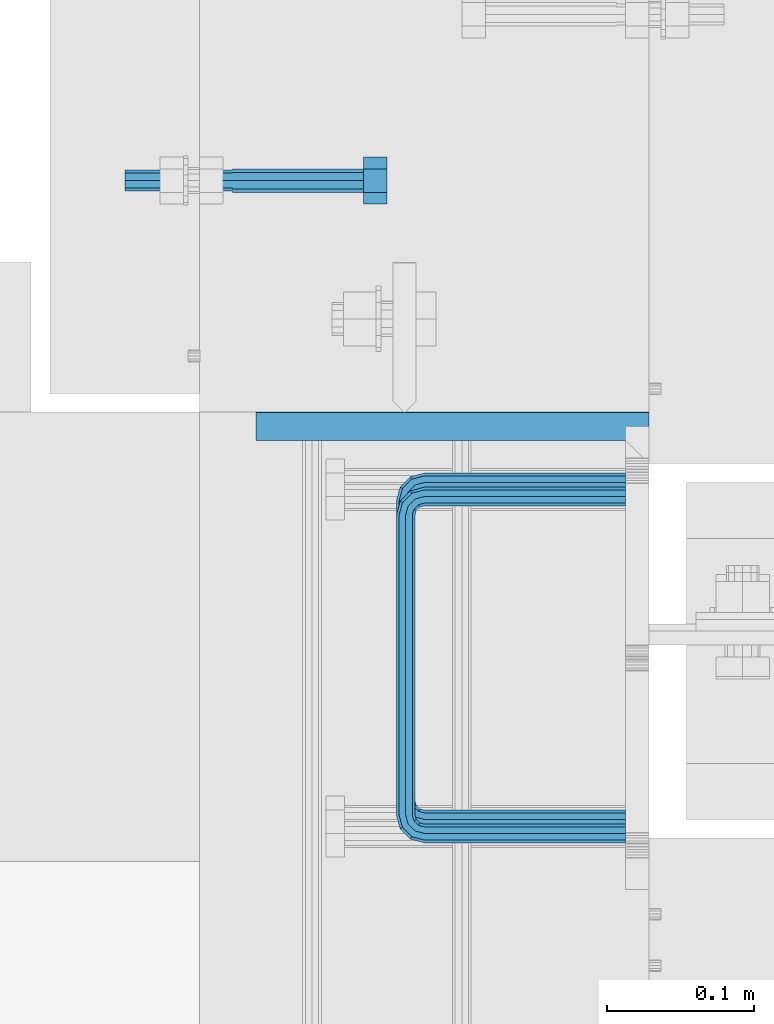
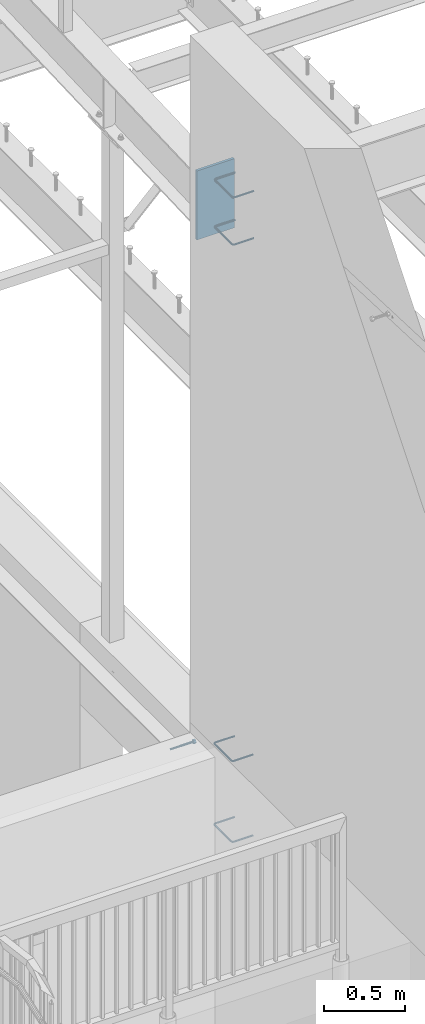
# One storey, part 380 of 975: 6 beams.
"""IFC2X3 building model written with IfcOpenShell, lengths in millimetres."""

from ifc_helpers import new_model, si_unit, frame, origin_with_axes, place, context, subcontext, project, spatial, faceted_brep, material, type_object, element, save


model = new_model("IFC2X3")

# Units and contexts
model_context = context("Model", 3, precision=1e-05, world=origin_with_axes())
body_context = subcontext(model_context, "Body", "Model", "MODEL_VIEW")
ifc_project = project(units=[si_unit("LENGTHUNIT", "METRE", prefix="MILLI"), si_unit("AREAUNIT", "SQUARE_METRE"), si_unit("VOLUMEUNIT", "CUBIC_METRE"), si_unit("MASSUNIT", "GRAM", prefix="KILO"), si_unit("TIMEUNIT", "SECOND"), si_unit("PLANEANGLEUNIT", "RADIAN"), si_unit("SOLIDANGLEUNIT", "STERADIAN"), si_unit("THERMODYNAMICTEMPERATUREUNIT", "DEGREE_CELSIUS"), si_unit("LUMINOUSINTENSITYUNIT", "LUMEN")], contexts=[model_context])

# Site, building, storey
site_placement = place(None, origin_with_axes())
site = spatial("IfcSite", under=ifc_project, at=site_placement, CompositionType="ELEMENT")
building_placement = place(site_placement, origin_with_axes())
building = spatial("IfcBuilding", under=site, at=building_placement, Name="Undefined", CompositionType="ELEMENT")
storey_placement = place(building_placement, origin_with_axes())
storey = spatial("IfcBuildingStorey", under=building, at=storey_placement, Name="Undefined", CompositionType="ELEMENT", Elevation=0.0)

# Beams
ifc_material_1 = material(Name="STEEL/F1554-36")
beam_type_1 = type_object("IfcBeamType", PredefinedType="NOTDEFINED")
beam_1_placement = place(storey_placement, frame((2038.34997213285, 6138.86245102515, 3835.4), z_axis=(0.0, 0.0, -1.0), x_axis=(1.0, 0.0, 0.0)))
element("IfcBeam", 1, at=beam_1_placement, inside=storey, type_object=beam_type_1, material=ifc_material_1, Name="HEADED_ANCHOR_BOLT", context=body_context, shape_type="Brep", body=[
    faceted_brep([(88.9000000184824, 7.94000001861696, -13.7499999799138), (88.8999999527368, 15.8800000758411, 2.00943759409711e-08), (104.774999952569, 15.8800001213949, 6.97191353538074e-08), (104.775000018315, 7.94000006417082, -13.7499999302891), (88.900000064019, -7.94000009583215, -13.7499999799147), (104.775000063852, -7.9400000502792, -13.74999993029), (88.9000000438027, -15.880000153059, 2.00925569515675e-08), (104.775000043643, -15.8800001075042, 6.9716406869702e-08), (88.8999999780608, -7.94000009583488, 13.7500000200998), (104.774999977893, -7.94000005028101, 13.7500000697237), (88.8999999325279, 7.94000001861514, 13.7500000201007), (104.774999932361, 7.940000064169, 13.7500000697246), (88.9000000119959, 3.78780480527439, -7.86545778426807), (88.8999999957159, 6.82538844544797, -5.4430656647246), (88.8999999799416, 8.51112018845743, -1.94260763148395), (88.8999999677944, 8.51112018845652, 1.94260767167179), (88.8999999616899, 6.82538844544615, 5.44306570491244), (88.8999999628249, 3.78780480527257, 7.86545782445592), (88.8999999709849, -3.86089595849626e-08, 8.72999956233434), (88.8999999845473, -3.7878048824914, 7.8654578244541), (88.9000000008309, -6.82538852266407, 5.44306570491153), (88.9000000166052, -8.51112026567444, 1.94260767166998), (88.9000000287488, -8.51112026567353, -1.94260763148577), (88.9000000348606, -6.82538852266407, -5.44306566472642), (88.9000000337182, -3.78780488248958, -7.86545778426898), (88.9000000255583, -3.86080500902608e-08, -8.72999952214832), (104.775000025395, 6.94581103743985e-09, -8.72999947252447), (104.775000011829, 3.78780485082825, -7.86545773464422), (104.774999995549, 6.82538849100092, -5.44306561510075), (104.774999979774, 8.51112023401038, -1.9426075818601), (104.774999967627, 8.51112023401038, 1.94260772129564), (104.774999961523, 6.82538849100092, 5.44306575453629), (104.774999962658, 3.78780485082643, 7.86545787407977), (104.774999970818, 6.94399204803631e-09, 8.7299996119591), (104.77499998438, -3.78780483693754, 7.86545787407886), (104.775000000664, -6.82538847711112, 5.44306575453538), (104.775000016438, -8.51112022012057, 1.94260772129473), (104.775000028581, -8.51112022012057, -1.94260758186101), (104.775000034693, -6.82538847711021, -5.44306561510166), (104.775000033551, -3.78780483693663, -7.86545773464422), (-2.99107341561466e-07, -5.61266007567065, 5.61266007566792), (-4.22995071858168e-07, -7.93750000000728, 0.0), (104.774999998088, -7.93749999999, -4.45652403868735e-11), (104.774999998088, -5.61266007565791, 5.61266007562426), (-1.09139364212751e-11, 1.81898940354586e-12, 7.9375), (104.774999998095, 1.18234311230481e-11, 7.93749999995816), (2.99089151667431e-07, 5.61266007567428, 5.61266007566792), (104.774999998102, 5.61266007568065, 5.61266007562517), (4.22980519942939e-07, 7.93750000001091, 0.0), (104.77499999811, 7.93750000001364, -4.36557456851006e-11), (2.99089151667431e-07, 5.61266007567428, -5.61266007566792), (104.774999998102, 5.61266007568156, -5.61266007571339), (-1.09139364212751e-11, 1.81898940354586e-12, -7.9375), (104.774999998099, 1.2732925824821e-11, -7.93750000004547), (-73.0249999592124, 5.05157065939329, -5.0515715445581), (-73.0249999269472, -1.85405951924622e-07, -7.14400069976364), (-73.0249999328516, -5.0515710302052, -5.05157154455992), (-73.0249999734697, -7.14400018541073, -6.9975976657588e-07), (-73.0250000250016, -5.05157103020611, 5.05157014504039), (-73.0250000572705, -1.85406861419324e-07, 7.1439993002441), (-73.0250000513661, 5.05157065939238, 5.05157014503948), (-73.025000010748, 7.14399981459792, -6.99758857081179e-07), (0.00625003290042514, 5.05157085007795, -5.05157087849238), (0.00625006516929716, 5.27870724909008e-09, -7.1440000336961), (0.00625005926485755, -5.05157083952145, -5.05157087849329), (0.00625001864682417, -7.14399999472516, -3.36940502165817e-08), (0.00624996711121639, -5.05157083952145, 5.05157081110519), (0.00624993484598235, 5.2777977543883e-09, 7.14399996631164), (0.00624994074678398, 5.05157085007704, 5.05157081110701), (0.00624998136845534, 7.14400000528167, -3.36922312271781e-08), (-2.99107341561466e-07, -5.61266007567065, -5.61266007566792), (104.774999998092, -5.612660075657, -5.6126600757143)], [[[0, 1, 2, 3]], [[4, 0, 3, 5]], [[6, 4, 5, 7]], [[8, 6, 7, 9]], [[10, 8, 9, 11]], [[0, 4, 6, 8, 10, 1], [12, 13, 14, 15, 16, 17, 18, 19, 20, 21, 22, 23, 24, 25]], [[12, 25, 26, 27]], [[13, 12, 27, 28]], [[14, 13, 28, 29]], [[15, 14, 29, 30]], [[16, 15, 30, 31]], [[17, 16, 31, 32]], [[18, 17, 32, 33]], [[19, 18, 33, 34]], [[20, 19, 34, 35]], [[21, 20, 35, 36]], [[22, 21, 36, 37]], [[23, 22, 37, 38]], [[24, 23, 38, 39]], [[25, 24, 39, 26]], [[9, 7, 5, 3, 2, 11], [38, 37, 36, 35, 34, 33, 32, 31, 30, 29, 28, 27, 26, 39]], [[1, 10, 11, 2]], [[40, 41, 42, 43]], [[44, 40, 43, 45]], [[46, 44, 45, 47]], [[48, 46, 47, 49]], [[50, 48, 49, 51]], [[52, 50, 51, 53]], [[54, 55, 56, 57, 58, 59, 60, 61]], [[55, 54, 62, 63]], [[56, 55, 63, 64]], [[57, 56, 64, 65]], [[58, 57, 65, 66]], [[59, 58, 66, 67]], [[60, 59, 67, 68]], [[61, 60, 68, 69]], [[54, 61, 69, 62]], [[40, 44, 46, 48, 50, 52, 70, 41], [68, 67, 66, 65, 64, 63, 62, 69]], [[41, 70, 71, 42]], [[53, 51, 49, 47, 45, 43, 42, 71]], [[70, 52, 53, 71]]]),
])
ifc_material_2 = material(Name="STEEL/A706")
beam_type_2 = type_object("IfcBeamType", Name="#4 TIE", PredefinedType="NOTDEFINED")
beam_2_placement = place(storey_placement, frame((2305.0501035281, 5695.95000864899, 7839.07498779297), z_axis=(0.0, 1.0, 0.0), x_axis=(-0.999999999999998, 6.90000001668524e-08, 0.0)))
element("IfcBeam", 2, at=beam_2_placement, inside=storey, type_object=beam_type_2, material=ifc_material_2, Name="TIE ROD", ObjectType="#4 TIE", context=body_context, shape_type="Brep", body=[
    faceted_brep([(0.0, -6.34999999998763, -3.63797880709171e-12), (0.0, -4.49012806052269, -4.49012806054634), (136.525006144455, -4.49012806053452, -4.49012811661669), (136.525006146271, -6.35000000000036, -5.60821717954241e-08), (0.0, 7.27595761418343e-12, -6.35000000000764), (136.525006143703, 0.0, -6.35000005608254), (0.0, 4.49012806053724, -4.49012806053906), (136.525006144455, 4.49012806053452, -4.49012811661669), (0.0, 6.34999999999491, 5.45696821063757e-12), (136.525006146271, 6.35000000000036, -5.60821717954241e-08), (0.0, 4.49012806052633, 4.49012806054634), (136.525006148087, 4.49012806053452, 4.49012800445234), (0.0, 0.0, 6.35000000000764), (136.525006148839, 0.0, 6.34999994391819), (0.0, -4.49012806053361, 4.49012806053543), (136.525006148087, -4.49012806053452, 4.49012800445234), (146.050006113442, 0.0, -3.79778399058796), (145.120070138105, -4.49012806053452, -2.1870876464609), (142.875006094308, -6.35000000000036, 1.70147731239558), (140.62994205051, -4.49012806053452, 5.59004227125297), (139.700006075173, 0.0, 7.20073861538003), (140.62994205051, 4.49012806053452, 5.59004227125297), (142.875006094308, 6.35000000000036, 1.70147731239558), (145.120070138105, 4.49012806053452, -2.1870876464609), (151.412093644245, 4.49012806053452, 4.10493592790226), (153.022789998455, 0.0, 3.1749999700296), (147.523528661045, 6.35000000000036, 6.34999992953635), (143.634963677846, 4.49012806053452, 8.59506393117135), (142.024267323636, 0.0, 9.5249998890431), (143.634963677846, -4.49012806053452, 8.59506393117135), (147.523528661045, -6.35000000000036, 6.34999992953635), (151.412093644245, -4.49012806053452, 4.10493592790226), (153.715134021207, 4.49012806053452, 12.6999999465306), (155.575005960673, 0.0, 12.6999999674508), (149.225005960672, 6.35000000000036, 12.6999998960273), (144.734877900137, 4.49012806053452, 12.699999845524), (142.875005960672, 0.0, 12.6999998246056), (144.734877900137, -4.49012806053452, 12.699999845524), (149.225005960671, -6.35000000000036, 12.6999998960273), (153.715134021207, -4.49012806053452, 12.6999999465306), (153.71513173569, -4.49012806053452, 215.900003176369), (149.225003675155, -6.35000000000036, 215.900003125867), (155.575003675155, 0.0, 215.900003197289), (153.71513173569, 4.49012806053452, 215.900003176369), (149.225003675155, 6.35000000000036, 215.900003125867), (144.734875614621, 4.49012806053452, 215.900003075363), (142.875003675155, 0.0, 215.900003054444), (144.734875614621, -4.49012806053452, 215.900003075363), (153.022787648382, 0.0, 225.425002877988), (151.412091300475, -4.49012806053452, 224.495066909199), (147.523526332491, -6.35000000000036, 222.25000288121), (143.634961364508, -4.49012806053452, 220.004938853222), (142.024265016601, 0.0, 219.075002884432), (143.634961364508, 4.49012806053452, 220.004938853222), (147.523526332491, 6.35000000000036, 222.25000288121), (151.412091300475, 4.49012806053452, 224.495066909199), (145.120067985683, 4.49012806053452, 230.787090305822), (146.05000397542, 0.0, 232.397786641635), (142.875003907121, 6.35000000000036, 226.898525367037), (140.629939828559, 4.49012806053452, 223.00996042825), (139.700003838822, 0.0, 221.399264092438), (140.629939828559, -4.49012806053452, 223.00996042825), (142.875003907121, -6.35000000000036, 226.898525367037), (145.120067985683, -4.49012806053452, 230.787090305822), (136.525004282814, 4.49012806053452, 233.090130852819), (136.525004327922, 0.0, 234.950002792285), (136.525004173912, 6.35000000000036, 228.600002792285), (136.52500406501, 4.49012806053452, 224.10987473175), (136.525004019901, 0.0, 222.250002792285), (136.52500406501, -4.49012806053452, 224.10987473175), (136.525004173912, -6.35000000000036, 228.600002792286), (136.525004282814, -4.49012806053452, 233.090130852819), (3.32236731992452e-06, -4.49012806053452, 233.090134164055), (3.21346533382894e-06, -6.35000000000036, 228.60000610352), (3.36747552864836e-06, 0.0, 234.95000610352), (3.32236731992452e-06, 4.49012806053452, 233.090134164055), (3.21346533382894e-06, 6.35000000000036, 228.60000610352), (3.104562892986e-06, 4.49012806053452, 224.109878042986), (3.05945422951481e-06, 0.0, 222.25000610352), (3.104562892986e-06, -4.49012806053452, 224.109878042986)], [[[0, 1, 2, 3]], [[1, 4, 5, 2]], [[4, 6, 7, 5]], [[6, 8, 9, 7]], [[8, 10, 11, 9]], [[10, 12, 13, 11]], [[12, 14, 15, 13]], [[14, 0, 3, 15]], [[14, 12, 10, 8, 6, 4, 1, 0]], [[2, 5, 16, 17]], [[3, 2, 17, 18]], [[15, 3, 18, 19]], [[13, 15, 19, 20]], [[11, 13, 20, 21]], [[9, 11, 21, 22]], [[7, 9, 22, 23]], [[5, 7, 23, 16]], [[23, 24, 25, 16]], [[22, 26, 24, 23]], [[21, 27, 26, 22]], [[20, 28, 27, 21]], [[19, 29, 28, 20]], [[18, 30, 29, 19]], [[17, 31, 30, 18]], [[16, 25, 31, 17]], [[24, 32, 33, 25]], [[26, 34, 32, 24]], [[27, 35, 34, 26]], [[28, 36, 35, 27]], [[29, 37, 36, 28]], [[30, 38, 37, 29]], [[31, 39, 38, 30]], [[25, 33, 39, 31]], [[38, 39, 40, 41]], [[39, 33, 42, 40]], [[33, 32, 43, 42]], [[32, 34, 44, 43]], [[34, 35, 45, 44]], [[35, 36, 46, 45]], [[36, 37, 47, 46]], [[37, 38, 41, 47]], [[40, 42, 48, 49]], [[41, 40, 49, 50]], [[47, 41, 50, 51]], [[46, 47, 51, 52]], [[45, 46, 52, 53]], [[44, 45, 53, 54]], [[43, 44, 54, 55]], [[42, 43, 55, 48]], [[55, 56, 57, 48]], [[54, 58, 56, 55]], [[53, 59, 58, 54]], [[52, 60, 59, 53]], [[51, 61, 60, 52]], [[50, 62, 61, 51]], [[49, 63, 62, 50]], [[48, 57, 63, 49]], [[56, 64, 65, 57]], [[58, 66, 64, 56]], [[59, 67, 66, 58]], [[60, 68, 67, 59]], [[61, 69, 68, 60]], [[62, 70, 69, 61]], [[63, 71, 70, 62]], [[57, 65, 71, 63]], [[70, 71, 72, 73]], [[71, 65, 74, 72]], [[65, 64, 75, 74]], [[64, 66, 76, 75]], [[66, 67, 77, 76]], [[67, 68, 78, 77]], [[68, 69, 79, 78]], [[69, 70, 73, 79]], [[74, 75, 76, 77, 78, 79, 73, 72]]]),
])
beam_3_placement = place(storey_placement, frame((2305.0501035281, 5695.95000864899, 8194.675), z_axis=(0.0, 1.0, 0.0), x_axis=(-0.999999999999998, 6.90000001668524e-08, 0.0)))
element("IfcBeam", 3, at=beam_3_placement, inside=storey, type_object=beam_type_2, material=ifc_material_2, Name="TIE ROD", ObjectType="#4 TIE", context=body_context, shape_type="Brep", body=[
    faceted_brep([(0.0, -6.34999999998763, -3.63797880709171e-12), (0.0, -4.49012806052269, -4.49012806054634), (136.525006144455, -4.49012806053452, -4.49012811661669), (136.525006146271, -6.35000000000036, -5.60821717954241e-08), (0.0, 7.27595761418343e-12, -6.35000000000764), (136.525006143703, 0.0, -6.35000005608254), (0.0, 4.49012806053724, -4.49012806053906), (136.525006144455, 4.49012806053452, -4.49012811661669), (0.0, 6.34999999999491, 5.45696821063757e-12), (136.525006146271, 6.35000000000036, -5.60821717954241e-08), (0.0, 4.49012806052633, 4.49012806054634), (136.525006148087, 4.49012806053452, 4.49012800445234), (0.0, 0.0, 6.35000000000764), (136.525006148839, 0.0, 6.34999994391819), (0.0, -4.49012806053361, 4.49012806053543), (136.525006148087, -4.49012806053452, 4.49012800445234), (146.050006113442, 0.0, -3.79778399058796), (145.120070138105, -4.49012806053452, -2.1870876464609), (142.875006094308, -6.35000000000036, 1.70147731239558), (140.62994205051, -4.49012806053452, 5.59004227125297), (139.700006075173, 0.0, 7.20073861538003), (140.62994205051, 4.49012806053452, 5.59004227125297), (142.875006094308, 6.35000000000036, 1.70147731239558), (145.120070138105, 4.49012806053452, -2.1870876464609), (151.412093644245, 4.49012806053452, 4.10493592790226), (153.022789998455, 0.0, 3.1749999700296), (147.523528661045, 6.35000000000036, 6.34999992953635), (143.634963677846, 4.49012806053452, 8.59506393117135), (142.024267323636, 0.0, 9.5249998890431), (143.634963677846, -4.49012806053452, 8.59506393117135), (147.523528661045, -6.35000000000036, 6.34999992953635), (151.412093644245, -4.49012806053452, 4.10493592790226), (153.715134021207, 4.49012806053452, 12.6999999465306), (155.575005960673, 0.0, 12.6999999674508), (149.225005960672, 6.35000000000036, 12.6999998960273), (144.734877900137, 4.49012806053452, 12.699999845524), (142.875005960672, 0.0, 12.6999998246056), (144.734877900137, -4.49012806053452, 12.699999845524), (149.225005960671, -6.35000000000036, 12.6999998960273), (153.715134021207, -4.49012806053452, 12.6999999465306), (153.71513173569, -4.49012806053452, 215.900003176369), (149.225003675155, -6.35000000000036, 215.900003125867), (155.575003675155, 0.0, 215.900003197289), (153.71513173569, 4.49012806053452, 215.900003176369), (149.225003675155, 6.35000000000036, 215.900003125867), (144.734875614621, 4.49012806053452, 215.900003075363), (142.875003675155, 0.0, 215.900003054444), (144.734875614621, -4.49012806053452, 215.900003075363), (153.022787648382, 0.0, 225.425002877988), (151.412091300475, -4.49012806053452, 224.495066909199), (147.523526332491, -6.35000000000036, 222.25000288121), (143.634961364508, -4.49012806053452, 220.004938853222), (142.024265016601, 0.0, 219.075002884432), (143.634961364508, 4.49012806053452, 220.004938853222), (147.523526332491, 6.35000000000036, 222.25000288121), (151.412091300475, 4.49012806053452, 224.495066909199), (145.120067985683, 4.49012806053452, 230.787090305822), (146.05000397542, 0.0, 232.397786641635), (142.875003907121, 6.35000000000036, 226.898525367037), (140.629939828559, 4.49012806053452, 223.00996042825), (139.700003838822, 0.0, 221.399264092438), (140.629939828559, -4.49012806053452, 223.00996042825), (142.875003907121, -6.35000000000036, 226.898525367037), (145.120067985683, -4.49012806053452, 230.787090305822), (136.525004282814, 4.49012806053452, 233.090130852819), (136.525004327922, 0.0, 234.950002792285), (136.525004173912, 6.35000000000036, 228.600002792285), (136.52500406501, 4.49012806053452, 224.10987473175), (136.525004019901, 0.0, 222.250002792285), (136.52500406501, -4.49012806053452, 224.10987473175), (136.525004173912, -6.35000000000036, 228.600002792286), (136.525004282814, -4.49012806053452, 233.090130852819), (3.32236731992452e-06, -4.49012806053452, 233.090134164055), (3.21346533382894e-06, -6.35000000000036, 228.60000610352), (3.36747552864836e-06, 0.0, 234.95000610352), (3.32236731992452e-06, 4.49012806053452, 233.090134164055), (3.21346533382894e-06, 6.35000000000036, 228.60000610352), (3.104562892986e-06, 4.49012806053452, 224.109878042986), (3.05945422951481e-06, 0.0, 222.25000610352), (3.104562892986e-06, -4.49012806053452, 224.109878042986)], [[[0, 1, 2, 3]], [[1, 4, 5, 2]], [[4, 6, 7, 5]], [[6, 8, 9, 7]], [[8, 10, 11, 9]], [[10, 12, 13, 11]], [[12, 14, 15, 13]], [[14, 0, 3, 15]], [[14, 12, 10, 8, 6, 4, 1, 0]], [[2, 5, 16, 17]], [[3, 2, 17, 18]], [[15, 3, 18, 19]], [[13, 15, 19, 20]], [[11, 13, 20, 21]], [[9, 11, 21, 22]], [[7, 9, 22, 23]], [[5, 7, 23, 16]], [[23, 24, 25, 16]], [[22, 26, 24, 23]], [[21, 27, 26, 22]], [[20, 28, 27, 21]], [[19, 29, 28, 20]], [[18, 30, 29, 19]], [[17, 31, 30, 18]], [[16, 25, 31, 17]], [[24, 32, 33, 25]], [[26, 34, 32, 24]], [[27, 35, 34, 26]], [[28, 36, 35, 27]], [[29, 37, 36, 28]], [[30, 38, 37, 29]], [[31, 39, 38, 30]], [[25, 33, 39, 31]], [[38, 39, 40, 41]], [[39, 33, 42, 40]], [[33, 32, 43, 42]], [[32, 34, 44, 43]], [[34, 35, 45, 44]], [[35, 36, 46, 45]], [[36, 37, 47, 46]], [[37, 38, 41, 47]], [[40, 42, 48, 49]], [[41, 40, 49, 50]], [[47, 41, 50, 51]], [[46, 47, 51, 52]], [[45, 46, 52, 53]], [[44, 45, 53, 54]], [[43, 44, 54, 55]], [[42, 43, 55, 48]], [[55, 56, 57, 48]], [[54, 58, 56, 55]], [[53, 59, 58, 54]], [[52, 60, 59, 53]], [[51, 61, 60, 52]], [[50, 62, 61, 51]], [[49, 63, 62, 50]], [[48, 57, 63, 49]], [[56, 64, 65, 57]], [[58, 66, 64, 56]], [[59, 67, 66, 58]], [[60, 68, 67, 59]], [[61, 69, 68, 60]], [[62, 70, 69, 61]], [[63, 71, 70, 62]], [[57, 65, 71, 63]], [[70, 71, 72, 73]], [[71, 65, 74, 72]], [[65, 64, 75, 74]], [[64, 66, 76, 75]], [[66, 67, 77, 76]], [[67, 68, 78, 77]], [[68, 69, 79, 78]], [[69, 70, 73, 79]], [[74, 75, 76, 77, 78, 79, 73, 72]]]),
])
beam_4_placement = place(storey_placement, frame((2305.05000045165, 5705.47499694824, 3330.57501220703), z_axis=(0.0, 1.0, 0.0), x_axis=(-0.999999999999998, 6.90000001668524e-08, 0.0)))
element("IfcBeam", 4, at=beam_4_placement, inside=storey, type_object=beam_type_2, material=ifc_material_2, Name="TIE ROD", ObjectType="#4 TIE", context=body_context, shape_type="Brep", body=[
    faceted_brep([(0.0, -6.34999999998763, -3.63797880709171e-12), (0.0, -4.49012806052269, -4.49012806054634), (136.525006144455, -4.49012806053452, -4.49012811661669), (136.525006146271, -6.35000000000036, -5.60821717954241e-08), (0.0, 7.27595761418343e-12, -6.35000000000764), (136.525006143703, 0.0, -6.35000005608254), (0.0, 4.49012806053724, -4.49012806053906), (136.525006144455, 4.49012806053452, -4.49012811661669), (0.0, 6.34999999999491, 5.45696821063757e-12), (136.525006146271, 6.35000000000036, -5.60821717954241e-08), (0.0, 4.49012806052633, 4.49012806054634), (136.525006148087, 4.49012806053452, 4.49012800445234), (0.0, 0.0, 6.35000000000764), (136.525006148839, 0.0, 6.34999994391819), (0.0, -4.49012806053361, 4.49012806053543), (136.525006148087, -4.49012806053452, 4.49012800445234), (146.050006113442, 0.0, -3.79778399058796), (145.120070138105, -4.49012806053452, -2.1870876464609), (142.875006094308, -6.35000000000036, 1.70147731239558), (140.62994205051, -4.49012806053452, 5.59004227125297), (139.700006075173, 0.0, 7.20073861538003), (140.62994205051, 4.49012806053452, 5.59004227125297), (142.875006094308, 6.35000000000036, 1.70147731239558), (145.120070138105, 4.49012806053452, -2.1870876464609), (151.412093644245, 4.49012806053452, 4.10493592790226), (153.022789998455, 0.0, 3.1749999700296), (147.523528661045, 6.35000000000036, 6.34999992953635), (143.634963677846, 4.49012806053452, 8.59506393117135), (142.024267323636, 0.0, 9.5249998890431), (143.634963677846, -4.49012806053452, 8.59506393117135), (147.523528661045, -6.35000000000036, 6.34999992953635), (151.412093644245, -4.49012806053452, 4.10493592790226), (153.715134021207, 4.49012806053452, 12.6999999465306), (155.575005960673, 0.0, 12.6999999674508), (149.225005960672, 6.35000000000036, 12.6999998960273), (144.734877900137, 4.49012806053452, 12.699999845524), (142.875005960672, 0.0, 12.6999998246056), (144.734877900137, -4.49012806053452, 12.699999845524), (149.225005960671, -6.35000000000036, 12.6999998960273), (153.715134021207, -4.49012806053452, 12.6999999465306), (153.71513173569, -4.49012806053452, 215.900003176369), (149.225003675155, -6.35000000000036, 215.900003125867), (155.575003675155, 0.0, 215.900003197289), (153.71513173569, 4.49012806053452, 215.900003176369), (149.225003675155, 6.35000000000036, 215.900003125867), (144.734875614621, 4.49012806053452, 215.900003075363), (142.875003675155, 0.0, 215.900003054444), (144.734875614621, -4.49012806053452, 215.900003075363), (153.022787648382, 0.0, 225.425002877988), (151.412091300475, -4.49012806053452, 224.495066909199), (147.523526332491, -6.35000000000036, 222.25000288121), (143.634961364508, -4.49012806053452, 220.004938853222), (142.024265016601, 0.0, 219.075002884432), (143.634961364508, 4.49012806053452, 220.004938853222), (147.523526332491, 6.35000000000036, 222.25000288121), (151.412091300475, 4.49012806053452, 224.495066909199), (145.120067985683, 4.49012806053452, 230.787090305822), (146.05000397542, 0.0, 232.397786641635), (142.875003907121, 6.35000000000036, 226.898525367037), (140.629939828559, 4.49012806053452, 223.00996042825), (139.700003838822, 0.0, 221.399264092438), (140.629939828559, -4.49012806053452, 223.00996042825), (142.875003907121, -6.35000000000036, 226.898525367037), (145.120067985683, -4.49012806053452, 230.787090305822), (136.525004282814, 4.49012806053452, 233.090130852819), (136.525004327922, 0.0, 234.950002792285), (136.525004173912, 6.35000000000036, 228.600002792285), (136.52500406501, 4.49012806053452, 224.10987473175), (136.525004019901, 0.0, 222.250002792285), (136.52500406501, -4.49012806053452, 224.10987473175), (136.525004173912, -6.35000000000036, 228.600002792286), (136.525004282814, -4.49012806053452, 233.090130852819), (3.32236731992452e-06, -4.49012806053452, 233.090134164055), (3.21346533382894e-06, -6.35000000000036, 228.60000610352), (3.36747552864836e-06, 0.0, 234.95000610352), (3.32236731992452e-06, 4.49012806053452, 233.090134164055), (3.21346533382894e-06, 6.35000000000036, 228.60000610352), (3.104562892986e-06, 4.49012806053452, 224.109878042986), (3.05945422951481e-06, 0.0, 222.25000610352), (3.104562892986e-06, -4.49012806053452, 224.109878042986)], [[[0, 1, 2, 3]], [[1, 4, 5, 2]], [[4, 6, 7, 5]], [[6, 8, 9, 7]], [[8, 10, 11, 9]], [[10, 12, 13, 11]], [[12, 14, 15, 13]], [[14, 0, 3, 15]], [[14, 12, 10, 8, 6, 4, 1, 0]], [[2, 5, 16, 17]], [[3, 2, 17, 18]], [[15, 3, 18, 19]], [[13, 15, 19, 20]], [[11, 13, 20, 21]], [[9, 11, 21, 22]], [[7, 9, 22, 23]], [[5, 7, 23, 16]], [[23, 24, 25, 16]], [[22, 26, 24, 23]], [[21, 27, 26, 22]], [[20, 28, 27, 21]], [[19, 29, 28, 20]], [[18, 30, 29, 19]], [[17, 31, 30, 18]], [[16, 25, 31, 17]], [[24, 32, 33, 25]], [[26, 34, 32, 24]], [[27, 35, 34, 26]], [[28, 36, 35, 27]], [[29, 37, 36, 28]], [[30, 38, 37, 29]], [[31, 39, 38, 30]], [[25, 33, 39, 31]], [[38, 39, 40, 41]], [[39, 33, 42, 40]], [[33, 32, 43, 42]], [[32, 34, 44, 43]], [[34, 35, 45, 44]], [[35, 36, 46, 45]], [[36, 37, 47, 46]], [[37, 38, 41, 47]], [[40, 42, 48, 49]], [[41, 40, 49, 50]], [[47, 41, 50, 51]], [[46, 47, 51, 52]], [[45, 46, 52, 53]], [[44, 45, 53, 54]], [[43, 44, 54, 55]], [[42, 43, 55, 48]], [[55, 56, 57, 48]], [[54, 58, 56, 55]], [[53, 59, 58, 54]], [[52, 60, 59, 53]], [[51, 61, 60, 52]], [[50, 62, 61, 51]], [[49, 63, 62, 50]], [[48, 57, 63, 49]], [[56, 64, 65, 57]], [[58, 66, 64, 56]], [[59, 67, 66, 58]], [[60, 68, 67, 59]], [[61, 69, 68, 60]], [[62, 70, 69, 61]], [[63, 71, 70, 62]], [[57, 65, 71, 63]], [[70, 71, 72, 73]], [[71, 65, 74, 72]], [[65, 64, 75, 74]], [[64, 66, 76, 75]], [[66, 67, 77, 76]], [[67, 68, 78, 77]], [[68, 69, 79, 78]], [[69, 70, 73, 79]], [[74, 75, 76, 77, 78, 79, 73, 72]]]),
])
beam_5_placement = place(storey_placement, frame((2305.05000094437, 5705.47499694824, 3940.175), z_axis=(0.0, 1.0, 0.0), x_axis=(-0.999999999999998, 6.90000001668524e-08, 0.0)))
element("IfcBeam", 5, at=beam_5_placement, inside=storey, type_object=beam_type_2, material=ifc_material_2, Name="TIE ROD", ObjectType="#4 TIE", context=body_context, shape_type="Brep", body=[
    faceted_brep([(0.0, -6.34999999998763, -3.63797880709171e-12), (0.0, -4.49012806052269, -4.49012806054634), (136.525006144455, -4.49012806053452, -4.49012811661669), (136.525006146271, -6.35000000000036, -5.60821717954241e-08), (0.0, 7.27595761418343e-12, -6.35000000000764), (136.525006143703, 0.0, -6.35000005608254), (0.0, 4.49012806053724, -4.49012806053906), (136.525006144455, 4.49012806053452, -4.49012811661669), (0.0, 6.34999999999491, 5.45696821063757e-12), (136.525006146271, 6.35000000000036, -5.60821717954241e-08), (0.0, 4.49012806052633, 4.49012806054634), (136.525006148087, 4.49012806053452, 4.49012800445234), (0.0, 0.0, 6.35000000000764), (136.525006148839, 0.0, 6.34999994391819), (0.0, -4.49012806053361, 4.49012806053543), (136.525006148087, -4.49012806053452, 4.49012800445234), (146.050006113442, 0.0, -3.79778399058796), (145.120070138105, -4.49012806053452, -2.1870876464609), (142.875006094308, -6.35000000000036, 1.70147731239558), (140.62994205051, -4.49012806053452, 5.59004227125297), (139.700006075173, 0.0, 7.20073861538003), (140.62994205051, 4.49012806053452, 5.59004227125297), (142.875006094308, 6.35000000000036, 1.70147731239558), (145.120070138105, 4.49012806053452, -2.1870876464609), (151.412093644245, 4.49012806053452, 4.10493592790226), (153.022789998455, 0.0, 3.1749999700296), (147.523528661045, 6.35000000000036, 6.34999992953635), (143.634963677846, 4.49012806053452, 8.59506393117135), (142.024267323636, 0.0, 9.5249998890431), (143.634963677846, -4.49012806053452, 8.59506393117135), (147.523528661045, -6.35000000000036, 6.34999992953635), (151.412093644245, -4.49012806053452, 4.10493592790226), (153.715134021207, 4.49012806053452, 12.6999999465306), (155.575005960673, 0.0, 12.6999999674508), (149.225005960672, 6.35000000000036, 12.6999998960273), (144.734877900137, 4.49012806053452, 12.699999845524), (142.875005960672, 0.0, 12.6999998246056), (144.734877900137, -4.49012806053452, 12.699999845524), (149.225005960671, -6.35000000000036, 12.6999998960273), (153.715134021207, -4.49012806053452, 12.6999999465306), (153.71513173569, -4.49012806053452, 215.900003176369), (149.225003675155, -6.35000000000036, 215.900003125867), (155.575003675155, 0.0, 215.900003197289), (153.71513173569, 4.49012806053452, 215.900003176369), (149.225003675155, 6.35000000000036, 215.900003125867), (144.734875614621, 4.49012806053452, 215.900003075363), (142.875003675155, 0.0, 215.900003054444), (144.734875614621, -4.49012806053452, 215.900003075363), (153.022787648382, 0.0, 225.425002877988), (151.412091300475, -4.49012806053452, 224.495066909199), (147.523526332491, -6.35000000000036, 222.25000288121), (143.634961364508, -4.49012806053452, 220.004938853222), (142.024265016601, 0.0, 219.075002884432), (143.634961364508, 4.49012806053452, 220.004938853222), (147.523526332491, 6.35000000000036, 222.25000288121), (151.412091300475, 4.49012806053452, 224.495066909199), (145.120067985683, 4.49012806053452, 230.787090305822), (146.05000397542, 0.0, 232.397786641635), (142.875003907121, 6.35000000000036, 226.898525367037), (140.629939828559, 4.49012806053452, 223.00996042825), (139.700003838822, 0.0, 221.399264092438), (140.629939828559, -4.49012806053452, 223.00996042825), (142.875003907121, -6.35000000000036, 226.898525367037), (145.120067985683, -4.49012806053452, 230.787090305822), (136.525004282814, 4.49012806053452, 233.090130852819), (136.525004327922, 0.0, 234.950002792285), (136.525004173912, 6.35000000000036, 228.600002792285), (136.52500406501, 4.49012806053452, 224.10987473175), (136.525004019901, 0.0, 222.250002792285), (136.52500406501, -4.49012806053452, 224.10987473175), (136.525004173912, -6.35000000000036, 228.600002792286), (136.525004282814, -4.49012806053452, 233.090130852819), (3.32236731992452e-06, -4.49012806053452, 233.090134164055), (3.21346533382894e-06, -6.35000000000036, 228.60000610352), (3.36747552864836e-06, 0.0, 234.95000610352), (3.32236731992452e-06, 4.49012806053452, 233.090134164055), (3.21346533382894e-06, 6.35000000000036, 228.60000610352), (3.104562892986e-06, 4.49012806053452, 224.109878042986), (3.05945422951481e-06, 0.0, 222.25000610352), (3.104562892986e-06, -4.49012806053452, 224.109878042986)], [[[0, 1, 2, 3]], [[1, 4, 5, 2]], [[4, 6, 7, 5]], [[6, 8, 9, 7]], [[8, 10, 11, 9]], [[10, 12, 13, 11]], [[12, 14, 15, 13]], [[14, 0, 3, 15]], [[14, 12, 10, 8, 6, 4, 1, 0]], [[2, 5, 16, 17]], [[3, 2, 17, 18]], [[15, 3, 18, 19]], [[13, 15, 19, 20]], [[11, 13, 20, 21]], [[9, 11, 21, 22]], [[7, 9, 22, 23]], [[5, 7, 23, 16]], [[23, 24, 25, 16]], [[22, 26, 24, 23]], [[21, 27, 26, 22]], [[20, 28, 27, 21]], [[19, 29, 28, 20]], [[18, 30, 29, 19]], [[17, 31, 30, 18]], [[16, 25, 31, 17]], [[24, 32, 33, 25]], [[26, 34, 32, 24]], [[27, 35, 34, 26]], [[28, 36, 35, 27]], [[29, 37, 36, 28]], [[30, 38, 37, 29]], [[31, 39, 38, 30]], [[25, 33, 39, 31]], [[38, 39, 40, 41]], [[39, 33, 42, 40]], [[33, 32, 43, 42]], [[32, 34, 44, 43]], [[34, 35, 45, 44]], [[35, 36, 46, 45]], [[36, 37, 47, 46]], [[37, 38, 41, 47]], [[40, 42, 48, 49]], [[41, 40, 49, 50]], [[47, 41, 50, 51]], [[46, 47, 51, 52]], [[45, 46, 52, 53]], [[44, 45, 53, 54]], [[43, 44, 54, 55]], [[42, 43, 55, 48]], [[55, 56, 57, 48]], [[54, 58, 56, 55]], [[53, 59, 58, 54]], [[52, 60, 59, 53]], [[51, 61, 60, 52]], [[50, 62, 61, 51]], [[49, 63, 62, 50]], [[48, 57, 63, 49]], [[56, 64, 65, 57]], [[58, 66, 64, 56]], [[59, 67, 66, 58]], [[60, 68, 67, 59]], [[61, 69, 68, 60]], [[62, 70, 69, 61]], [[63, 71, 70, 62]], [[57, 65, 71, 63]], [[70, 71, 72, 73]], [[71, 65, 74, 72]], [[65, 64, 75, 74]], [[64, 66, 76, 75]], [[66, 67, 77, 76]], [[67, 68, 78, 77]], [[68, 69, 79, 78]], [[69, 70, 73, 79]], [[74, 75, 76, 77, 78, 79, 73, 72]]]),
])
ifc_material_3 = material(Name="STEEL/A36")
beam_type_3 = type_object("IfcBeamType", PredefinedType="NOTDEFINED")
beam_6_placement = place(storey_placement, frame((2187.57509948069, 5971.93406034841, 8270.40438836301), z_axis=(-0.999999999999998, 6.90000001668524e-08, 0.0), x_axis=(0.0, 0.00052226699980215, -0.999999863618581)))
element("IfcBeam", 6, at=beam_6_placement, inside=storey, type_object=beam_type_3, material=ifc_material_3, Name="PLATE", context=body_context, shape_type="Brep", body=[
    faceted_brep([(9.09494701772928e-12, 9.52499999999964, -133.35), (9.09494701772928e-12, 9.52499999999964, 133.35), (520.700000000204, 9.52500000003874, 133.35), (520.700000000204, 9.52500000003874, -133.35), (-7.27595761418343e-12, -9.52499999999964, 133.35), (520.700000000188, -9.52499999995962, 133.35), (-7.27595761418343e-12, -9.52499999999964, -133.35), (520.700000000188, -9.52499999995962, -133.35)], [[[0, 1, 2, 3]], [[1, 4, 5, 2]], [[4, 6, 7, 5]], [[6, 0, 3, 7]], [[5, 7, 3, 2]], [[6, 4, 1, 0]]]),
])

save(model, "model.ifc")
